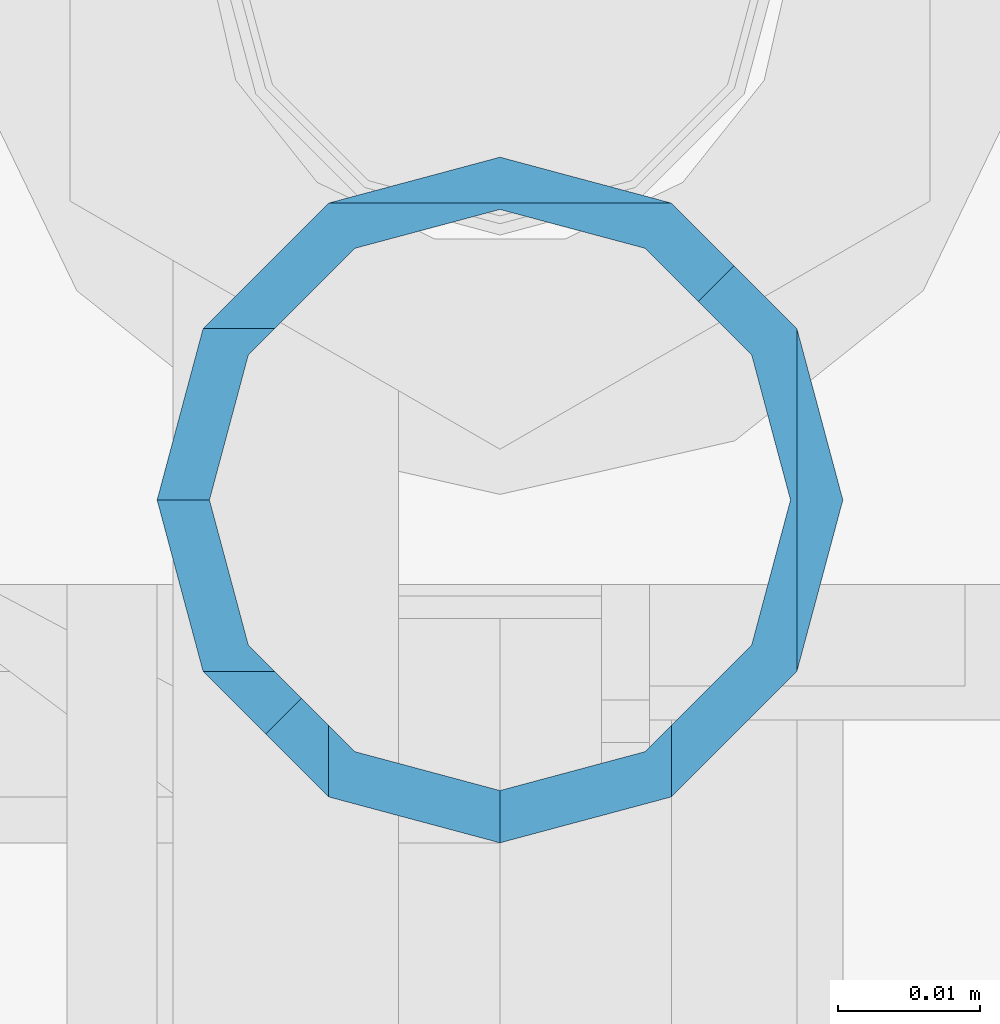
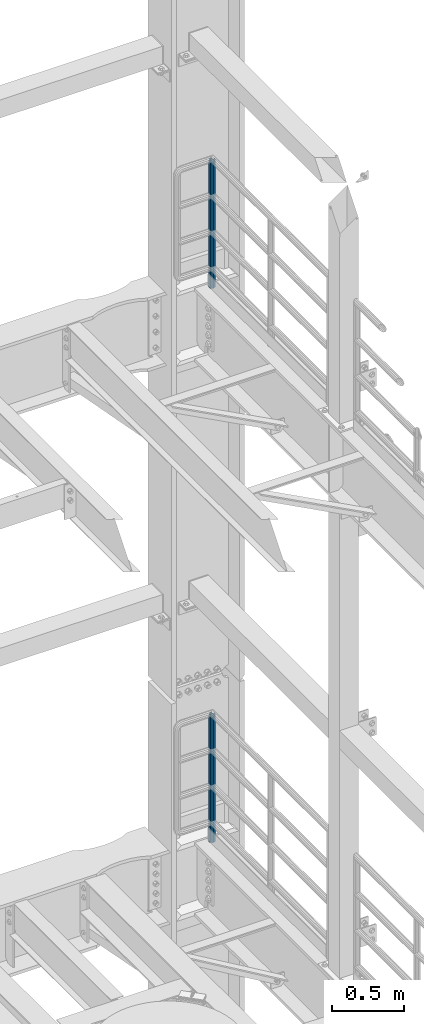
# One storey, part 771 of 1876: 2 columns, 2 elements without a shape of their own.
"""IFC2X3 building model written with IfcOpenShell, lengths in millimetres."""

from ifc_helpers import new_model, si_unit, frame, origin_with_axes, place, context, subcontext, project, spatial, faceted_brep, material, type_object, element, aggregate, save


model = new_model("IFC2X3")

# Units and contexts
model_context = context("Model", 3, precision=1e-05, world=origin_with_axes())
body_context = subcontext(model_context, "Body", "Model", "MODEL_VIEW")
ifc_project = project(units=[si_unit("LENGTHUNIT", "METRE", prefix="MILLI"), si_unit("AREAUNIT", "SQUARE_METRE"), si_unit("VOLUMEUNIT", "CUBIC_METRE"), si_unit("MASSUNIT", "GRAM", prefix="KILO"), si_unit("TIMEUNIT", "SECOND"), si_unit("PLANEANGLEUNIT", "RADIAN"), si_unit("SOLIDANGLEUNIT", "STERADIAN"), si_unit("THERMODYNAMICTEMPERATUREUNIT", "DEGREE_CELSIUS"), si_unit("LUMINOUSINTENSITYUNIT", "LUMEN")], contexts=[model_context])

# Site, building, storey
site_placement = place(None, origin_with_axes())
site = spatial("IfcSite", under=ifc_project, at=site_placement, CompositionType="ELEMENT")
building_placement = place(site_placement, origin_with_axes())
building = spatial("IfcBuilding", under=site, at=building_placement, Name="Undefined", CompositionType="ELEMENT")
storey_placement = place(building_placement, origin_with_axes())
storey = spatial("IfcBuildingStorey", under=building, at=storey_placement, Name="Undefined", CompositionType="ELEMENT", Elevation=0.0)

# Assembly, column
assembly_1_placement = place(storey_placement, origin_with_axes())
assembly_1 = element("IfcElementAssembly", 1, at=assembly_1_placement, inside=storey, Name="RAIL", AssemblyPlace="NOTDEFINED", PredefinedType="RIGID_FRAME")
ifc_material = material()
column_type = type_object("IfcColumnType", Name="PIPE1-1/2SCH40", PredefinedType="NOTDEFINED")
column_1_placement = place(assembly_1_placement, frame((7620.0, 13499.7063, 17983.2), z_axis=(0.0, 1.0, 0.0), x_axis=(0.0, 0.0, 1.0)))
column_1 = element("IfcColumn", 2, at=column_1_placement, type_object=column_type, material=ifc_material, Name="POST", ObjectType="PIPE1-1/2SCH40", context=body_context, shape_type="Brep", body=[
    faceted_brep([(1076.325, 24.1300000000001, 0.0), (1064.26, 20.8971929933184, 12.0649999999996), (1064.25999999999, 20.8971929933186, -12.0649999999996), (1059.84389372958, 16.4810867391689, 16.4811062541503), (1057.32835795224, 13.9655509593422, 13.9655704718371), (1061.07042843786, 17.7076214311803, 10.2235000000001), (1063.80980700668, 20.4469999999999, 0.0), (1061.07042843786, 17.7076214311803, -10.2235000000001), (1055.42780700668, 12.0650000000001, -15.8661214311805), (1055.42780700667, 12.0649999999996, -20.8971929933186), (1054.93437856882, 10.2235000000001, -17.7076214311801), (1052.195, 0.0, -20.4470000000001), (1052.19499999999, 0.0, -24.1300000000001), (1055.42780700668, -12.0650000000001, -15.8661214311805), (1055.42780700667, -12.0649999999996, -20.8971929933186), (1054.93437856882, -10.2235000000001, -17.7076214311801), (1057.32837749231, -13.9655704718352, -13.9655509593449), (1059.84391327711, -16.4811062541476, -16.4810867391716), (1055.42780700668, -15.8661214311742, -12.065000000006), (1055.42780700668, -20.8971929933184, -12.0649999999996), (1054.93437856882, -17.7076214311801, -10.2235000000001), (1052.195, -20.4470000000001, 0.0), (1052.195, -24.1300000000001, 0.0), (1054.93437856882, -17.7076214311801, 10.2235000000001), (1055.42780700668, -15.8661214311869, 12.0649999999932), (1055.42780700668, -20.8971929933184, 12.0649999999996), (1076.325, 0.0, 24.1300000000001), (1064.26, -12.0650000000001, 20.8971929933186), (1064.26, 12.065, 20.8971929933186), (1061.07042843787, -10.2235000000001, 17.7076214311801), (1063.80980700669, 0.0, 20.4470000000001), (1061.07042843787, 10.2235000000001, 17.7076214311801), (0.0, -20.8971929933184, -12.0649999999996), (0.0, -12.0650000000001, -20.8971929933186), (-1.45519152283669e-11, 0.0, -24.130000000001), (0.0, 12.0650000000001, -20.8971929933186), (0.0, 20.8971929933184, -12.0649999999996), (0.0, 24.1299999999992, 0.0), (0.0, 20.8971929933184, 12.0649999999996), (0.0, 12.0650000000001, 20.8971929933186), (-1.45519152283669e-11, 0.0, 24.130000000001), (0.0, -20.8971929933184, 12.0649999999996), (0.0, -24.1299999999992, 0.0), (0.0, -12.0650000000001, 20.8971929933186), (0.0, -17.7076214311803, -10.2235000000001), (0.0, -10.2235000000001, -17.7076214311801), (-1.45519152283669e-11, 0.0, -20.4470000000001), (0.0, 10.2235000000001, -17.7076214311801), (0.0, 17.7076214311803, -10.2235000000001), (0.0, 20.4469999999999, 0.0), (0.0, 17.7076214311803, 10.2235000000001), (0.0, 10.2235000000001, 17.7076214311801), (-1.45519152283669e-11, 0.0, 20.4470000000001), (0.0, -10.2235000000001, 17.7076214311801), (0.0, -17.7076214311803, 10.2235000000001), (0.0, -20.4469999999999, 0.0)], [[[0, 1, 2]], [[3, 4, 5, 6, 7, 8, 9, 2, 1]], [[10, 11, 12, 9, 8]], [[13, 14, 12, 11, 15]], [[14, 13, 16, 17]], [[17, 16, 18, 19]], [[19, 18, 20, 21, 22]], [[22, 21, 23, 24, 25]], [[26, 27, 28]], [[25, 24, 29, 30, 31, 4, 3, 28, 27]], [[32, 33, 14, 17, 19]], [[33, 34, 12, 14]], [[34, 35, 9, 12]], [[35, 36, 2, 9]], [[36, 37, 0, 2]], [[37, 38, 1, 0]], [[1, 38, 39, 28, 3]], [[39, 40, 26, 28]], [[41, 42, 22, 25]], [[43, 41, 25, 27]], [[40, 43, 27, 26]], [[42, 32, 19, 22]], [[41, 43, 40, 39, 38, 37, 36, 35, 34, 33, 32, 42], [44, 45, 46, 47, 48, 49, 50, 51, 52, 53, 54, 55]], [[53, 52, 30, 29]], [[23, 54, 53, 29, 24]], [[55, 54, 23, 21]], [[44, 55, 21, 20]], [[15, 45, 44, 20, 18, 16, 13]], [[46, 45, 15, 11]], [[47, 46, 11, 10]], [[48, 47, 10, 8, 7]], [[49, 48, 7, 6]], [[50, 49, 6, 5]], [[51, 50, 5, 4, 31]], [[52, 51, 31, 30]]]),
])
aggregate(assembly_1, [column_1])

assembly_2_placement = place(storey_placement, origin_with_axes())
assembly_2 = element("IfcElementAssembly", 3, at=assembly_2_placement, inside=storey, Name="RAIL", AssemblyPlace="NOTDEFINED", PredefinedType="RIGID_FRAME")
column_2_placement = place(assembly_2_placement, frame((7620.0, 13499.7063, 13309.6), z_axis=(0.0, 1.0, 0.0), x_axis=(0.0, 0.0, 1.0)))
column_2 = element("IfcColumn", 4, at=column_2_placement, type_object=column_type, material=ifc_material, Name="POST", ObjectType="PIPE1-1/2SCH40", context=body_context, shape_type="Brep", body=[
    faceted_brep([(1076.325, 24.1300000000001, 0.0), (1064.26, 20.8971929933184, 12.0649999999996), (1064.25999999999, 20.8971929933186, -12.0649999999996), (1059.84389372958, 16.4810867391689, 16.4811062541503), (1057.32835795224, 13.9655509593422, 13.9655704718371), (1061.07042843786, 17.7076214311803, 10.2235000000001), (1063.80980700668, 20.4469999999999, 0.0), (1061.07042843786, 17.7076214311803, -10.2235000000001), (1055.42780700668, 12.0650000000001, -15.8661214311805), (1055.42780700667, 12.0649999999996, -20.8971929933186), (1054.93437856882, 10.2235000000001, -17.7076214311801), (1052.195, 0.0, -20.4470000000001), (1052.19499999999, 0.0, -24.1300000000001), (1055.42780700668, -12.0650000000001, -15.8661214311805), (1055.42780700667, -12.0649999999996, -20.8971929933186), (1054.93437856882, -10.2235000000001, -17.7076214311801), (1057.32837749231, -13.9655704718352, -13.9655509593449), (1059.84391327711, -16.4811062541476, -16.4810867391716), (1055.42780700668, -15.8661214311742, -12.065000000006), (1055.42780700668, -20.8971929933184, -12.0649999999996), (1054.93437856882, -17.7076214311801, -10.2235000000001), (1052.195, -20.4470000000001, 0.0), (1052.195, -24.1300000000001, 0.0), (1054.93437856882, -17.7076214311801, 10.2235000000001), (1055.42780700668, -15.8661214311869, 12.0649999999932), (1055.42780700668, -20.8971929933184, 12.0649999999996), (1076.325, 0.0, 24.1300000000001), (1064.26, -12.0650000000001, 20.8971929933186), (1064.26, 12.065, 20.8971929933186), (1061.07042843787, -10.2235000000001, 17.7076214311801), (1063.80980700669, 0.0, 20.4470000000001), (1061.07042843787, 10.2235000000001, 17.7076214311801), (0.0, -20.8971929933184, -12.0649999999996), (0.0, -12.0650000000001, -20.8971929933186), (-1.45519152283669e-11, 0.0, -24.130000000001), (0.0, 12.0650000000001, -20.8971929933186), (0.0, 20.8971929933184, -12.0649999999996), (0.0, 24.1299999999992, 0.0), (0.0, 20.8971929933184, 12.0649999999996), (0.0, 12.0650000000001, 20.8971929933186), (-1.45519152283669e-11, 0.0, 24.130000000001), (0.0, -20.8971929933184, 12.0649999999996), (0.0, -24.1299999999992, 0.0), (0.0, -12.0650000000001, 20.8971929933186), (0.0, -17.7076214311803, -10.2235000000001), (0.0, -10.2235000000001, -17.7076214311801), (-1.45519152283669e-11, 0.0, -20.4470000000001), (0.0, 10.2235000000001, -17.7076214311801), (0.0, 17.7076214311803, -10.2235000000001), (0.0, 20.4469999999999, 0.0), (0.0, 17.7076214311803, 10.2235000000001), (0.0, 10.2235000000001, 17.7076214311801), (-1.45519152283669e-11, 0.0, 20.4470000000001), (0.0, -10.2235000000001, 17.7076214311801), (0.0, -17.7076214311803, 10.2235000000001), (0.0, -20.4469999999999, 0.0)], [[[0, 1, 2]], [[3, 4, 5, 6, 7, 8, 9, 2, 1]], [[10, 11, 12, 9, 8]], [[13, 14, 12, 11, 15]], [[14, 13, 16, 17]], [[17, 16, 18, 19]], [[19, 18, 20, 21, 22]], [[22, 21, 23, 24, 25]], [[26, 27, 28]], [[25, 24, 29, 30, 31, 4, 3, 28, 27]], [[32, 33, 14, 17, 19]], [[33, 34, 12, 14]], [[34, 35, 9, 12]], [[35, 36, 2, 9]], [[36, 37, 0, 2]], [[37, 38, 1, 0]], [[1, 38, 39, 28, 3]], [[39, 40, 26, 28]], [[41, 42, 22, 25]], [[43, 41, 25, 27]], [[40, 43, 27, 26]], [[42, 32, 19, 22]], [[41, 43, 40, 39, 38, 37, 36, 35, 34, 33, 32, 42], [44, 45, 46, 47, 48, 49, 50, 51, 52, 53, 54, 55]], [[53, 52, 30, 29]], [[23, 54, 53, 29, 24]], [[55, 54, 23, 21]], [[44, 55, 21, 20]], [[15, 45, 44, 20, 18, 16, 13]], [[46, 45, 15, 11]], [[47, 46, 11, 10]], [[48, 47, 10, 8, 7]], [[49, 48, 7, 6]], [[50, 49, 6, 5]], [[51, 50, 5, 4, 31]], [[52, 51, 31, 30]]]),
])
aggregate(assembly_2, [column_2])

save(model, "model.ifc")
